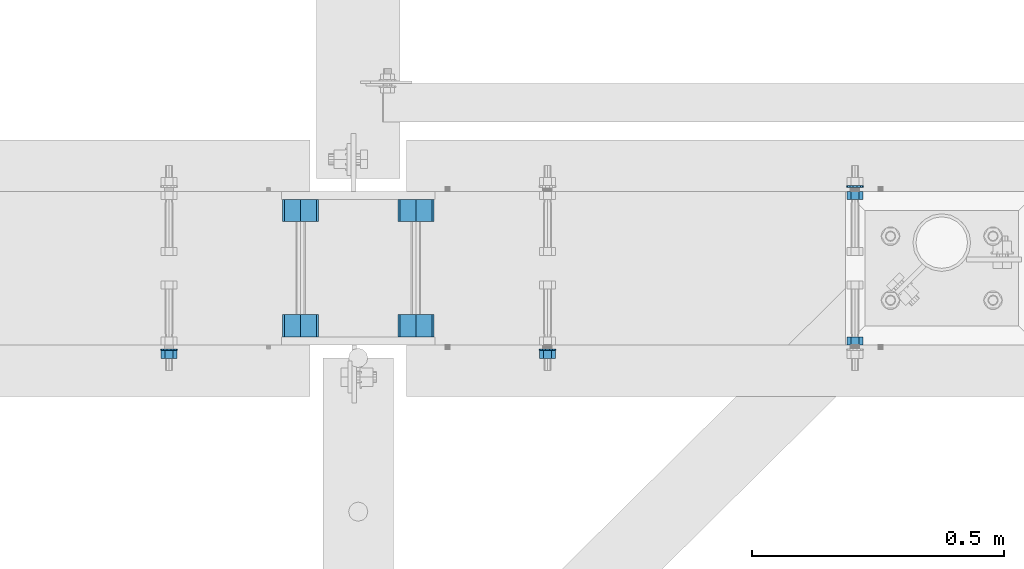
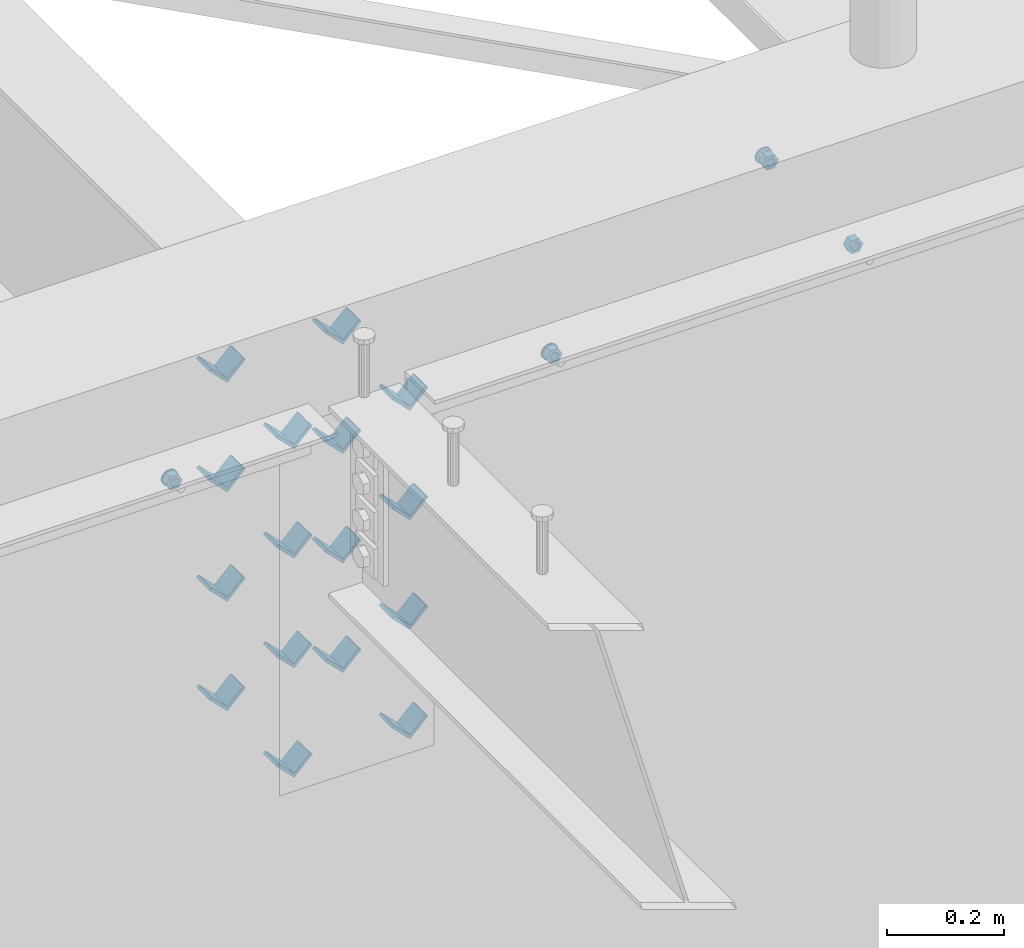
# One storey, part 606 of 975: 23 beams.
"""IFC2X3 building model written with IfcOpenShell, lengths in millimetres."""

import ifcopenshell
import ifcopenshell.guid

model = None  # the IFC model being written
_history = None  # IfcOwnerHistory: only IFC2X3 demands one
_inside = {}  # id of a spatial element -> (the spatial element, [elements in it])
_under = {}  # id of a project, library or spatial element -> (it, [spatial elements below it])
_declared = {}  # id of a project -> (the project, [libraries it declares])
_typed = {}  # id of a type object -> (the type object, [elements of that type])
_made_of = {}  # id of a material, layer set ... -> (it, [elements and type objects made of it])


def new_model(schema):
    """Start an empty IFC model of exactly this schema.

    Asked for "IFC4X3", IfcOpenShell would pick the latest addendum, in which some entities
    have other attributes; the version numbers below select the first issue.
    IFC2X3 requires an IfcOwnerHistory on every rooted entity: one is made here for all.
    """
    global model, _history
    if schema == "IFC4X3":
        model = ifcopenshell.file(schema_version=(4, 3, 0, 0))
    else:
        model = ifcopenshell.file(schema=schema)
    _inside.clear()
    _under.clear()
    _declared.clear()
    _typed.clear()
    _made_of.clear()
    _history = None
    if model.schema == "IFC2X3":
        org = make("IfcOrganization", Name="unknown")
        user = make(
            "IfcPersonAndOrganization",
            ThePerson=make("IfcPerson", FamilyName="unknown"),
            TheOrganization=org,
        )
        app = make(
            "IfcApplication",
            ApplicationDeveloper=org,
            Version="unknown",
            ApplicationFullName="unknown",
            ApplicationIdentifier="unknown",
        )
        _history = make(
            "IfcOwnerHistory",
            OwningUser=user,
            OwningApplication=app,
            ChangeAction="ADDED",
            CreationDate=0,
        )
    return model


def make(cls, **values):
    """One entity of the class cls with the attributes given. An attribute that is None is left unset."""
    return model.create_entity(
        cls, **{name: value for name, value in values.items() if value is not None}
    )


def rooted(cls, **values):
    """An entity with a GlobalId (a new one), such as an element, a storey or a relation."""
    return make(cls, GlobalId=ifcopenshell.guid.new(), OwnerHistory=_history, **values)


def si_unit(unit_type, name, prefix=None):
    """IfcSIUnit, for example si_unit("LENGTHUNIT", "METRE", prefix="MILLI")."""
    return make("IfcSIUnit", UnitType=unit_type, Prefix=prefix, Name=name)


def assignment(units):
    """IfcUnitAssignment: the units of a project."""
    return None if units is None else make("IfcUnitAssignment", Units=units)


def point(xyz):
    """IfcCartesianPoint."""
    return None if xyz is None else make("IfcCartesianPoint", Coordinates=xyz)


def direction(xyz):
    """IfcDirection."""
    return None if xyz is None else make("IfcDirection", DirectionRatios=xyz)


def frame(location, z_axis=None, x_axis=None):
    """IfcAxis2Placement3D, a coordinate frame: its origin and axes. An axis left out is left unset."""
    return make(
        "IfcAxis2Placement3D",
        Location=point(location),
        Axis=direction(z_axis),
        RefDirection=direction(x_axis),
    )


def origin_with_axes():
    """The frame at (0, 0, 0) with the z axis (0, 0, 1) and the x axis (1, 0, 0) written out."""
    return frame((0.0, 0.0, 0.0), z_axis=(0.0, 0.0, 1.0), x_axis=(1.0, 0.0, 0.0))


def place(relative_to, where):
    """IfcLocalPlacement: puts the frame where relative to a parent placement (None: the world)."""
    return make(
        "IfcLocalPlacement", PlacementRelTo=relative_to, RelativePlacement=where
    )


def context(
    kind, dimensions, precision=None, world=None, true_north=None, identifier=None
):
    """IfcGeometricRepresentationContext, for example the 3D "Model" context."""
    return make(
        "IfcGeometricRepresentationContext",
        ContextIdentifier=identifier,
        ContextType=kind,
        CoordinateSpaceDimension=dimensions,
        Precision=precision,
        WorldCoordinateSystem=world,
        TrueNorth=true_north,
    )


def subcontext(parent, identifier, kind, view, scale=None):
    """IfcGeometricRepresentationSubContext, for example "Body" below "Model"."""
    return make(
        "IfcGeometricRepresentationSubContext",
        ContextIdentifier=identifier,
        ContextType=kind,
        ParentContext=parent,
        TargetScale=scale,
        TargetView=view,
    )


def project(units=None, contexts=None):
    """IfcProject with its units and contexts."""
    return rooted(
        "IfcProject",
        Name="project",
        RepresentationContexts=contexts,
        UnitsInContext=assignment(units),
    )


def spatial(cls, under=None, at=None, **own):
    """A site, building, storey or space (cls), placed at a placement, below another one or the project."""
    s = rooted(cls, ObjectPlacement=at, **own)
    if under is not None:
        _under.setdefault(under.id(), (under, []))[1].append(s)
    return s


def faces_of(points, faces, orient=None, outer=None):
    """IfcFace entities. A face is a list of loops; a loop is a list of indices into points, from 0.

    orient and outer hold one flag for each loop. By default every Orientation is true, the
    first loop of a face is its IfcFaceOuterBound and the others are IfcFaceBound.
    """
    made = []
    for i, loops in enumerate(faces):
        bounds = []
        for j, loop in enumerate(loops):
            is_outer = j == 0 if outer is None else outer[i][j]
            bounds.append(
                make(
                    "IfcFaceOuterBound" if is_outer else "IfcFaceBound",
                    Bound=make("IfcPolyLoop", Polygon=[points[k] for k in loop]),
                    Orientation=True if orient is None else orient[i][j],
                )
            )
        made.append(make("IfcFace", Bounds=bounds))
    return made


def faceted_brep(points, faces, orient=None, outer=None, voids=None):
    """IfcFacetedBrep: a solid bounded by flat faces; with voids (closed shells), ...WithVoids."""
    shared = [point(p) for p in points]
    hull = make("IfcClosedShell", CfsFaces=faces_of(shared, faces, orient, outer))
    if voids is None:
        return make("IfcFacetedBrep", Outer=hull)
    return make(
        "IfcFacetedBrepWithVoids",
        Outer=hull,
        Voids=[
            make(cls, CfsFaces=faces_of(shared, fs, o, b)) for cls, fs, o, b in voids
        ],
    )


def shape(context_of_items, identifier, shape_type, items):
    """IfcShapeRepresentation: the items that make up one representation, for example the "Body"."""
    return make(
        "IfcShapeRepresentation",
        ContextOfItems=context_of_items,
        RepresentationIdentifier=identifier,
        RepresentationType=shape_type,
        Items=items,
    )


def material(Name=None, Category=None):
    """IfcMaterial."""
    return make("IfcMaterial", Name=Name, Category=Category)


def made_of(thing, what):
    """Note that an element or type object is made of a material, layer set ...; save() writes the relation."""
    if what is not None:
        _made_of.setdefault(what.id(), (what, []))[1].append(thing)
    return thing


def type_object(cls, material=None, **own):
    """A type object (cls), such as IfcWallType, which elements share."""
    return made_of(rooted(cls, **own), material)


def element(
    cls,
    number,
    at=None,
    inside=None,
    cuts=None,
    type_object=None,
    material=None,
    context=None,
    identifier="Body",
    shape_type=None,
    held_by="IfcProductDefinitionShape",
    body=None,
    shapes=None,
    **own,
):
    """One element of the class cls, such as IfcWall. Its Tag is "e" and its number.

    at: its placement. inside: the storey or other place that contains it. cuts: it is an
    opening in that element (IfcRelVoidsElement). A single representation is given by context,
    identifier, shape_type and body (its items); several are given by shapes. held_by: the class
    of the entity that holds the representations. save() writes the other relations.
    """
    e = rooted(cls, Tag="e%d" % number, ObjectPlacement=at, **own)
    if body is not None:
        shapes = [shape(context, identifier, shape_type, body)]
    if shapes is not None:
        e.Representation = make(held_by, Representations=shapes)
    if inside is not None:
        _inside.setdefault(inside.id(), (inside, []))[1].append(e)
    if cuts is not None:
        rooted(
            "IfcRelVoidsElement", RelatingBuildingElement=cuts, RelatedOpeningElement=e
        )
    if type_object is not None:
        _typed.setdefault(type_object.id(), (type_object, []))[1].append(e)
    return made_of(e, material)


def aggregate(whole, parts):
    """IfcRelAggregates: a whole, such as a stair, and the parts it consists of."""
    return rooted("IfcRelAggregates", RelatingObject=whole, RelatedObjects=parts)


def save(model, path):
    """Write the relations noted so far, then the file.

    IfcRelAggregates (storeys below a building ...), IfcRelContainedInSpatialStructure (elements
    in a storey), IfcRelDefinesByType, IfcRelAssociatesMaterial and IfcRelDeclares: one each for
    every whole, place, type object, material and project.
    """
    for whole, parts in _under.values():
        aggregate(whole, parts)
    for where, things in _inside.values():
        rooted(
            "IfcRelContainedInSpatialStructure",
            RelatedElements=things,
            RelatingStructure=where,
        )
    for kind, things in _typed.values():
        rooted("IfcRelDefinesByType", RelatedObjects=things, RelatingType=kind)
    for what, things in _made_of.values():
        rooted("IfcRelAssociatesMaterial", RelatedObjects=things, RelatingMaterial=what)
    for by, libraries in _declared.values():
        rooted("IfcRelDeclares", RelatingContext=by, RelatedDefinitions=libraries)
    model.write(path)


model = new_model("IFC2X3")

# Units and contexts
model_context = context("Model", 3, precision=1e-05, world=origin_with_axes())
body_context = subcontext(model_context, "Body", "Model", "MODEL_VIEW")
ifc_project = project(units=[si_unit("LENGTHUNIT", "METRE", prefix="MILLI"), si_unit("AREAUNIT", "SQUARE_METRE"), si_unit("VOLUMEUNIT", "CUBIC_METRE"), si_unit("MASSUNIT", "GRAM", prefix="KILO"), si_unit("TIMEUNIT", "SECOND"), si_unit("PLANEANGLEUNIT", "RADIAN"), si_unit("SOLIDANGLEUNIT", "STERADIAN"), si_unit("THERMODYNAMICTEMPERATUREUNIT", "DEGREE_CELSIUS"), si_unit("LUMINOUSINTENSITYUNIT", "LUMEN")], contexts=[model_context])

# Site, building, storey
site_placement = place(None, origin_with_axes())
site = spatial("IfcSite", under=ifc_project, at=site_placement, CompositionType="ELEMENT")
building_placement = place(site_placement, origin_with_axes())
building = spatial("IfcBuilding", under=site, at=building_placement, Name="Undefined", CompositionType="ELEMENT")
storey_placement = place(building_placement, origin_with_axes())
storey = spatial("IfcBuildingStorey", under=building, at=storey_placement, Name="Undefined", CompositionType="ELEMENT", Elevation=0.0)

# Beams
ifc_material = material(Name="STEEL/A36")
beam_type_1 = type_object("IfcBeamType", Name="L2X2X1/4", PredefinedType="NOTDEFINED")
for number, where, z_axis, x_axis, name in (
    (1, (6145.7421482145, 20459.6337290899, 3417.06996517217), (-0.707106781186557, 0.0, 0.707106781186538), (0.0, 1.0, 0.0), "ANGLE"),
    (2, (6374.34214821451, 20459.6337290899, 3417.06996517217), (-0.707106781186557, 0.0, 0.707106781186538), (0.0, 1.0, 0.0), "ANGLE"),
    (3, (6145.7421482145, 20688.3662709102, 3417.06996517217), (-0.707106781186557, 0.0, 0.707106781186538), (0.0, 1.0, 0.0), "ANGLE"),
    (4, (6374.34214821451, 20688.3662709102, 3417.06996517217), (-0.707106781186557, 0.0, 0.707106781186538), (0.0, 1.0, 0.0), "ANGLE"),
    (5, (6145.7421482145, 20459.6337290899, 3645.66996517217), (-0.707106781186557, 0.0, 0.707106781186538), (0.0, 1.0, 0.0), "ANGLE"),
    (6, (6374.34214821451, 20459.6337290899, 3645.66996517217), (-0.707106781186557, 0.0, 0.707106781186538), (0.0, 1.0, 0.0), "ANGLE"),
    (7, (6145.7421482145, 20688.3662709102, 3645.66996517217), (-0.707106781186557, 0.0, 0.707106781186538), (0.0, 1.0, 0.0), "ANGLE"),
    (8, (6374.34214821451, 20688.3662709102, 3645.66996517217), (-0.707106781186557, 0.0, 0.707106781186538), (0.0, 1.0, 0.0), "ANGLE"),
    (9, (6145.74214821337, 20459.6337290899, 3188.4699651707), (-0.707106781186557, 0.0, 0.707106781186538), (0.0, 1.0, 0.0), "ANGLE"),
    (10, (6145.7421482145, 20459.6337290899, 3874.26996517217), (-0.707106781186557, 0.0, 0.707106781186538), (0.0, 1.0, 0.0), "ANGLE"),
    (11, (6374.34214821338, 20459.6337290899, 3188.4699651707), (-0.707106781186557, 0.0, 0.707106781186538), (0.0, 1.0, 0.0), "ANGLE"),
    (12, (6374.34214821451, 20459.6337290899, 3874.26996517217), (-0.707106781186557, 0.0, 0.707106781186538), (0.0, 1.0, 0.0), "ANGLE"),
    (13, (6145.74214821337, 20688.3662709102, 3188.4699651707), (-0.707106781186557, 0.0, 0.707106781186538), (0.0, 1.0, 0.0), "ANGLE"),
    (14, (6145.7421482145, 20688.3662709102, 3874.26996517217), (-0.707106781186557, 0.0, 0.707106781186538), (0.0, 1.0, 0.0), "ANGLE"),
    (15, (6374.34214821338, 20688.3662709102, 3188.4699651707), (-0.707106781186557, 0.0, 0.707106781186538), (0.0, 1.0, 0.0), "ANGLE"),
    (16, (6374.34214821451, 20688.3662709102, 3874.26996517217), (-0.707106781186557, 0.0, 0.707106781186538), (0.0, 1.0, 0.0), "ANGLE"),
):
    element("IfcBeam", number, at=place(storey_placement, frame(where, z_axis=z_axis, x_axis=x_axis)), inside=storey, type_object=beam_type_1, material=ifc_material, Name=name, ObjectType="L2X2X1/4", context=body_context, shape_type="Brep", body=[
        faceted_brep([(0.0, 25.3999999999724, -25.4000000000342), (0.0, 25.400000000016, 25.4000000000196), (44.4499999999971, 25.4000000000033, 25.4000000000051), (44.4499999999971, 25.4000000000033, -25.4000000000024), (3.27418092638254e-11, 19.0500000000002, 25.4000000000269), (44.4499999999971, 19.0500000000011, 25.400000000006), (-2.5465851649642e-11, 19.0500000000002, -19.0500000000211), (44.4499999999971, 19.0500000000011, -19.050000000002), (-2.5465851649642e-11, -25.3999999999996, -19.0500000000211), (44.4499999999971, -25.4000000000069, -19.0500000000038), (0.0, -25.400000000016, -25.4000000000196), (44.4499999999971, -25.4000000000069, -25.4000000000033)], [[[0, 1, 2, 3]], [[1, 4, 5, 2]], [[4, 6, 7, 5]], [[6, 8, 9, 7]], [[8, 10, 11, 9]], [[10, 0, 3, 11]], [[5, 7, 9, 11, 3, 2]], [[10, 8, 6, 4, 1, 0]]]),
    ])
beam_type_2 = type_object("IfcBeamType", Name="5/8_HEAVY_HEX_NUT", PredefinedType="NOTDEFINED")
beam_1_placement = place(storey_placement, frame((7244.82086460168, 20443.825, 3886.2), z_axis=(0.0, 0.0, -1.0), x_axis=(0.0, 1.0, 0.0)))
element("IfcBeam", 17, at=beam_1_placement, inside=storey, type_object=beam_type_2, material=ifc_material, Name="NUT", ObjectType="5/8_HEAVY_HEX_NUT", context=body_context, shape_type="Brep", body=[
    faceted_brep([(-1.09139364212751e-11, -15.8800001144436, -2.72848410531878e-12), (1.45519152283669e-11, -7.94000005722046, -13.7500000000036), (15.8750000000146, -7.94000005722137, -13.7500000000045), (15.8749999999891, -15.8800001144446, -2.72848410531878e-12), (2.91038304567337e-11, 7.94000005722319, -13.7500000000027), (15.8750000000291, 7.94000005722319, -13.7500000000027), (2.18278728425503e-11, 15.8800001144436, 9.09494701772928e-13), (15.8750000000218, 15.8800001144427, 9.09494701772928e-13), (-7.27595761418343e-12, 7.94000005722046, 13.7500000000027), (15.8749999999927, 7.94000005722046, 13.7500000000027), (-2.18278728425503e-11, -7.94000005722228, 13.7500000000009), (15.8749999999782, -7.94000005722319, 13.7500000000009), (-7.27595761418343e-12, 0.0, 8.72999954223724), (0.0, 3.78780484388062, 7.86545780435881), (15.875, 3.78780484387971, 7.86545780435881), (15.8749999999927, -9.09494701772928e-13, 8.72999954223724), (7.27595761418343e-12, 6.82538848405238, 5.44306568481716), (15.8750000000073, 6.82538848405238, 5.44306568481716), (1.09139364212751e-11, 8.51112022706275, 1.94260765157742), (15.8750000000109, 8.51112022706093, 1.94260765157651), (1.45519152283669e-11, 8.51112022706184, -1.94260765157651), (15.8750000000146, 8.51112022706184, -1.94260765157651), (2.18278728425503e-11, 6.8253884840542, -5.44306568481716), (15.8750000000218, 6.82538848405238, -5.44306568481716), (1.81898940354586e-11, 3.78780484388153, -7.86545780435881), (15.8750000000182, 3.78780484388062, -7.86545780435881), (1.81898940354586e-11, 9.09494701772928e-13, -8.72999954223997), (15.8750000000182, 9.09494701772928e-13, -8.72999954223997), (1.09139364212751e-11, -3.78780484387971, -7.86545780436063), (15.8750000000109, -3.78780484388062, -7.86545780436063), (3.63797880709171e-12, -6.82538848405238, -5.44306568481807), (15.8750000000036, -6.82538848405329, -5.44306568481807), (0.0, -8.51112022706184, -1.94260765157833), (15.875, -8.51112022706184, -1.94260765157833), (-7.27595761418343e-12, -8.51112022706184, 1.9426076515756), (15.8749999999927, -8.51112022706275, 1.9426076515756), (-1.09139364212751e-11, -6.82538848405329, 5.44306568481534), (15.8749999999927, -6.8253884840542, 5.44306568481534), (-7.27595761418343e-12, -3.78780484388062, 7.8654578043579), (15.8749999999927, -3.78780484388153, 7.8654578043579)], [[[0, 1, 2, 3]], [[1, 4, 5, 2]], [[4, 6, 7, 5]], [[6, 8, 9, 7]], [[8, 10, 11, 9]], [[10, 0, 3, 11]], [[12, 13, 14, 15]], [[13, 16, 17, 14]], [[16, 18, 19, 17]], [[18, 20, 21, 19]], [[20, 22, 23, 21]], [[22, 24, 25, 23]], [[24, 26, 27, 25]], [[26, 28, 29, 27]], [[28, 30, 31, 29]], [[30, 32, 33, 31]], [[32, 34, 35, 33]], [[34, 36, 37, 35]], [[36, 38, 39, 37]], [[38, 12, 15, 39]], [[5, 7, 9, 11, 3, 2], [17, 19, 21, 23, 25, 27, 29, 31, 33, 35, 37, 39, 15, 14]], [[10, 8, 6, 4, 1, 0], [38, 36, 34, 32, 30, 28, 26, 24, 22, 20, 18, 16, 13, 12]]]),
])
beam_2_placement = place(storey_placement, frame((7244.82086460168, 20748.6249996637, 3886.2), z_axis=(0.0, 0.0, 1.0), x_axis=(0.0, -1.0, 0.0)))
element("IfcBeam", 18, at=beam_2_placement, inside=storey, type_object=beam_type_2, material=ifc_material, Name="NUT", ObjectType="5/8_HEAVY_HEX_NUT", context=body_context, shape_type="Brep", body=[
    faceted_brep([(-1.09139364212751e-11, -15.8800001144436, -2.72848410531878e-12), (1.45519152283669e-11, -7.94000005722046, -13.7500000000036), (15.8750000000146, -7.94000005722137, -13.7500000000045), (15.8749999999891, -15.8800001144446, -2.72848410531878e-12), (2.91038304567337e-11, 7.94000005722319, -13.7500000000027), (15.8750000000291, 7.94000005722319, -13.7500000000027), (2.18278728425503e-11, 15.8800001144436, 9.09494701772928e-13), (15.8750000000218, 15.8800001144427, 9.09494701772928e-13), (-7.27595761418343e-12, 7.94000005722046, 13.7500000000027), (15.8749999999927, 7.94000005722046, 13.7500000000027), (-2.18278728425503e-11, -7.94000005722228, 13.7500000000009), (15.8749999999782, -7.94000005722319, 13.7500000000009), (-7.27595761418343e-12, 0.0, 8.72999954223724), (0.0, 3.78780484388062, 7.86545780435881), (15.875, 3.78780484387971, 7.86545780435881), (15.8749999999927, -9.09494701772928e-13, 8.72999954223724), (7.27595761418343e-12, 6.82538848405238, 5.44306568481716), (15.8750000000073, 6.82538848405238, 5.44306568481716), (1.09139364212751e-11, 8.51112022706275, 1.94260765157742), (15.8750000000109, 8.51112022706093, 1.94260765157651), (1.45519152283669e-11, 8.51112022706184, -1.94260765157651), (15.8750000000146, 8.51112022706184, -1.94260765157651), (2.18278728425503e-11, 6.8253884840542, -5.44306568481716), (15.8750000000218, 6.82538848405238, -5.44306568481716), (1.81898940354586e-11, 3.78780484388153, -7.86545780435881), (15.8750000000182, 3.78780484388062, -7.86545780435881), (1.81898940354586e-11, 9.09494701772928e-13, -8.72999954223997), (15.8750000000182, 9.09494701772928e-13, -8.72999954223997), (1.09139364212751e-11, -3.78780484387971, -7.86545780436063), (15.8750000000109, -3.78780484388062, -7.86545780436063), (3.63797880709171e-12, -6.82538848405238, -5.44306568481807), (15.8750000000036, -6.82538848405329, -5.44306568481807), (0.0, -8.51112022706184, -1.94260765157833), (15.875, -8.51112022706184, -1.94260765157833), (-7.27595761418343e-12, -8.51112022706184, 1.9426076515756), (15.8749999999927, -8.51112022706275, 1.9426076515756), (-1.09139364212751e-11, -6.82538848405329, 5.44306568481534), (15.8749999999927, -6.8253884840542, 5.44306568481534), (-7.27595761418343e-12, -3.78780484388062, 7.8654578043579), (15.8749999999927, -3.78780484388153, 7.8654578043579)], [[[0, 1, 2, 3]], [[1, 4, 5, 2]], [[4, 6, 7, 5]], [[6, 8, 9, 7]], [[8, 10, 11, 9]], [[10, 0, 3, 11]], [[12, 13, 14, 15]], [[13, 16, 17, 14]], [[16, 18, 19, 17]], [[18, 20, 21, 19]], [[20, 22, 23, 21]], [[22, 24, 25, 23]], [[24, 26, 27, 25]], [[26, 28, 29, 27]], [[28, 30, 31, 29]], [[30, 32, 33, 31]], [[32, 34, 35, 33]], [[34, 36, 37, 35]], [[36, 38, 39, 37]], [[38, 12, 15, 39]], [[5, 7, 9, 11, 3, 2], [17, 19, 21, 23, 25, 27, 29, 31, 33, 35, 37, 39, 15, 14]], [[10, 8, 6, 4, 1, 0], [38, 36, 34, 32, 30, 28, 26, 24, 22, 20, 18, 16, 13, 12]]]),
])
beam_3_placement = place(storey_placement, frame((6635.22088901577, 20416.8375, 3886.2), z_axis=(0.0, 0.0, -1.0), x_axis=(0.0, 1.0, 0.0)))
element("IfcBeam", 19, at=beam_3_placement, inside=storey, type_object=beam_type_2, material=ifc_material, Name="NUT", ObjectType="5/8_HEAVY_HEX_NUT", context=body_context, shape_type="Brep", body=[
    faceted_brep([(-1.09139364212751e-11, -15.8800001144436, -2.72848410531878e-12), (1.45519152283669e-11, -7.94000005722046, -13.7500000000036), (15.8750000000146, -7.94000005722137, -13.7500000000045), (15.8749999999891, -15.8800001144446, -2.72848410531878e-12), (2.91038304567337e-11, 7.94000005722319, -13.7500000000027), (15.8750000000291, 7.94000005722319, -13.7500000000027), (2.18278728425503e-11, 15.8800001144436, 9.09494701772928e-13), (15.8750000000218, 15.8800001144427, 9.09494701772928e-13), (-7.27595761418343e-12, 7.94000005722046, 13.7500000000027), (15.8749999999927, 7.94000005722046, 13.7500000000027), (-2.18278728425503e-11, -7.94000005722228, 13.7500000000009), (15.8749999999782, -7.94000005722319, 13.7500000000009), (-7.27595761418343e-12, 0.0, 8.72999954223724), (0.0, 3.78780484388062, 7.86545780435881), (15.875, 3.78780484387971, 7.86545780435881), (15.8749999999927, -9.09494701772928e-13, 8.72999954223724), (7.27595761418343e-12, 6.82538848405238, 5.44306568481716), (15.8750000000073, 6.82538848405238, 5.44306568481716), (1.09139364212751e-11, 8.51112022706275, 1.94260765157742), (15.8750000000109, 8.51112022706093, 1.94260765157651), (1.45519152283669e-11, 8.51112022706184, -1.94260765157651), (15.8750000000146, 8.51112022706184, -1.94260765157651), (2.18278728425503e-11, 6.8253884840542, -5.44306568481716), (15.8750000000218, 6.82538848405238, -5.44306568481716), (1.81898940354586e-11, 3.78780484388153, -7.86545780435881), (15.8750000000182, 3.78780484388062, -7.86545780435881), (1.81898940354586e-11, 9.09494701772928e-13, -8.72999954223997), (15.8750000000182, 9.09494701772928e-13, -8.72999954223997), (1.09139364212751e-11, -3.78780484387971, -7.86545780436063), (15.8750000000109, -3.78780484388062, -7.86545780436063), (3.63797880709171e-12, -6.82538848405238, -5.44306568481807), (15.8750000000036, -6.82538848405329, -5.44306568481807), (0.0, -8.51112022706184, -1.94260765157833), (15.875, -8.51112022706184, -1.94260765157833), (-7.27595761418343e-12, -8.51112022706184, 1.9426076515756), (15.8749999999927, -8.51112022706275, 1.9426076515756), (-1.09139364212751e-11, -6.82538848405329, 5.44306568481534), (15.8749999999927, -6.8253884840542, 5.44306568481534), (-7.27595761418343e-12, -3.78780484388062, 7.8654578043579), (15.8749999999927, -3.78780484388153, 7.8654578043579)], [[[0, 1, 2, 3]], [[1, 4, 5, 2]], [[4, 6, 7, 5]], [[6, 8, 9, 7]], [[8, 10, 11, 9]], [[10, 0, 3, 11]], [[12, 13, 14, 15]], [[13, 16, 17, 14]], [[16, 18, 19, 17]], [[18, 20, 21, 19]], [[20, 22, 23, 21]], [[22, 24, 25, 23]], [[24, 26, 27, 25]], [[26, 28, 29, 27]], [[28, 30, 31, 29]], [[30, 32, 33, 31]], [[32, 34, 35, 33]], [[34, 36, 37, 35]], [[36, 38, 39, 37]], [[38, 12, 15, 39]], [[5, 7, 9, 11, 3, 2], [17, 19, 21, 23, 25, 27, 29, 31, 33, 35, 37, 39, 15, 14]], [[10, 8, 6, 4, 1, 0], [38, 36, 34, 32, 30, 28, 26, 24, 22, 20, 18, 16, 13, 12]]]),
])
beam_4_placement = place(storey_placement, frame((5884.86256939268, 20416.8375, 3886.2), z_axis=(0.0, 0.0, 1.0), x_axis=(0.0, 1.0, 0.0)))
element("IfcBeam", 20, at=beam_4_placement, inside=storey, type_object=beam_type_2, material=ifc_material, Name="NUT", ObjectType="5/8_HEAVY_HEX_NUT", context=body_context, shape_type="Brep", body=[
    faceted_brep([(-1.09139364212751e-11, -15.8800001144436, -2.72848410531878e-12), (1.45519152283669e-11, -7.94000005722046, -13.7500000000036), (15.8750000000146, -7.94000005722137, -13.7500000000045), (15.8749999999891, -15.8800001144446, -2.72848410531878e-12), (2.91038304567337e-11, 7.94000005722319, -13.7500000000027), (15.8750000000291, 7.94000005722319, -13.7500000000027), (2.18278728425503e-11, 15.8800001144436, 9.09494701772928e-13), (15.8750000000218, 15.8800001144427, 9.09494701772928e-13), (-7.27595761418343e-12, 7.94000005722046, 13.7500000000027), (15.8749999999927, 7.94000005722046, 13.7500000000027), (-2.18278728425503e-11, -7.94000005722228, 13.7500000000009), (15.8749999999782, -7.94000005722319, 13.7500000000009), (-7.27595761418343e-12, 0.0, 8.72999954223724), (0.0, 3.78780484388062, 7.86545780435881), (15.875, 3.78780484387971, 7.86545780435881), (15.8749999999927, -9.09494701772928e-13, 8.72999954223724), (7.27595761418343e-12, 6.82538848405238, 5.44306568481716), (15.8750000000073, 6.82538848405238, 5.44306568481716), (1.09139364212751e-11, 8.51112022706275, 1.94260765157742), (15.8750000000109, 8.51112022706093, 1.94260765157651), (1.45519152283669e-11, 8.51112022706184, -1.94260765157651), (15.8750000000146, 8.51112022706184, -1.94260765157651), (2.18278728425503e-11, 6.8253884840542, -5.44306568481716), (15.8750000000218, 6.82538848405238, -5.44306568481716), (1.81898940354586e-11, 3.78780484388153, -7.86545780435881), (15.8750000000182, 3.78780484388062, -7.86545780435881), (1.81898940354586e-11, 9.09494701772928e-13, -8.72999954223997), (15.8750000000182, 9.09494701772928e-13, -8.72999954223997), (1.09139364212751e-11, -3.78780484387971, -7.86545780436063), (15.8750000000109, -3.78780484388062, -7.86545780436063), (3.63797880709171e-12, -6.82538848405238, -5.44306568481807), (15.8750000000036, -6.82538848405329, -5.44306568481807), (0.0, -8.51112022706184, -1.94260765157833), (15.875, -8.51112022706184, -1.94260765157833), (-7.27595761418343e-12, -8.51112022706184, 1.9426076515756), (15.8749999999927, -8.51112022706275, 1.9426076515756), (-1.09139364212751e-11, -6.82538848405329, 5.44306568481534), (15.8749999999927, -6.8253884840542, 5.44306568481534), (-7.27595761418343e-12, -3.78780484388062, 7.8654578043579), (15.8749999999927, -3.78780484388153, 7.8654578043579)], [[[0, 1, 2, 3]], [[1, 4, 5, 2]], [[4, 6, 7, 5]], [[6, 8, 9, 7]], [[8, 10, 11, 9]], [[10, 0, 3, 11]], [[12, 13, 14, 15]], [[13, 16, 17, 14]], [[16, 18, 19, 17]], [[18, 20, 21, 19]], [[20, 22, 23, 21]], [[22, 24, 25, 23]], [[24, 26, 27, 25]], [[26, 28, 29, 27]], [[28, 30, 31, 29]], [[30, 32, 33, 31]], [[32, 34, 35, 33]], [[34, 36, 37, 35]], [[36, 38, 39, 37]], [[38, 12, 15, 39]], [[5, 7, 9, 11, 3, 2], [17, 19, 21, 23, 25, 27, 29, 31, 33, 35, 37, 39, 15, 14]], [[10, 8, 6, 4, 1, 0], [38, 36, 34, 32, 30, 28, 26, 24, 22, 20, 18, 16, 13, 12]]]),
])
beam_type_3 = type_object("IfcBeamType", Name="5/8_WASHER", PredefinedType="NOTDEFINED")
beam_5_placement = place(storey_placement, frame((7244.82086460174, 20759.7375, 3886.2), z_axis=(0.0, 0.0, 1.0), x_axis=(0.0, -1.0, 0.0)))
element("IfcBeam", 21, at=beam_5_placement, inside=storey, type_object=beam_type_3, material=ifc_material, Name="WASHER", ObjectType="5/8_WASHER", context=body_context, shape_type="Brep", body=[
    faceted_brep([(1.09139364212751e-11, -16.670000076293, -2.72848410531878e-12), (2.18278728425503e-11, -15.0191510966704, -7.23284196419536), (3.1750000000211, -15.0191510966711, -7.23284196419627), (3.17500000001019, -16.6700000762937, -1.81898940354586e-12), (2.91038304567337e-11, -10.3935750445523, -13.0331308723944), (3.17500000002838, -10.3935750445526, -13.0331308723953), (2.91038304567337e-11, -3.70942398602756, -16.2520483704566), (3.17500000002838, -3.70942398602779, -16.2520483704566), (2.5465851649642e-11, 3.70942398602961, -16.2520483704557), (3.17500000002474, 3.70942398602961, -16.2520483704566), (1.45519152283669e-11, 10.3935750445542, -13.0331308723935), (3.17500000001382, 10.3935750445537, -13.0331308723944), (0.0, 15.0191510966717, -7.23284196419354), (3.17499999999927, 15.0191510966713, -7.23284196419354), (-7.27595761418343e-12, 16.6700000762933, 0.0), (3.174999999992, 16.6700000762928, -9.09494701772928e-13), (-1.81898940354586e-11, 15.0191510966706, 7.23284196419354), (3.17499999998108, 15.0191510966704, 7.23284196419354), (-2.5465851649642e-11, 10.3935750445519, 13.0331308723926), (3.17499999997381, 10.3935750445517, 13.0331308723926), (-2.5465851649642e-11, 3.70942398602733, 16.2520483704538), (3.17499999997381, 3.7094239860271, 16.2520483704529), (-2.18278728425503e-11, -3.70942398602983, 16.2520483704529), (3.17499999997744, -3.70942398603006, 16.2520483704538), (-1.09139364212751e-11, -10.3935750445542, 13.0331308723908), (3.17499999998836, -10.3935750445544, 13.0331308723908), (0.0, -15.0191510966717, 7.23284196419172), (3.17499999999927, -15.019151096672, 7.23284196419081), (-7.27595761418343e-12, 0.0, 8.72999954223724), (0.0, 3.78780484388062, 7.86545780435881), (3.17499999998472, 3.78780484387903, 7.86545780435699), (3.17499999998836, -9.09494701772928e-13, 8.72999954223542), (7.27595761418343e-12, 6.82538848405238, 5.44306568481716), (3.17499999998836, 6.82538848405102, 5.44306568481534), (1.09139364212751e-11, 8.51112022706275, 1.94260765157742), (3.174999999992, 8.51112022705979, 1.94260765157651), (1.45519152283669e-11, 8.51112022706184, -1.94260765157651), (3.17499999999563, 8.51112022706025, -1.94260765157742), (2.18278728425503e-11, 6.8253884840542, -5.44306568481716), (3.17500000000655, 6.8253884840517, -5.44306568481807), (1.81898940354586e-11, 3.78780484388153, -7.86545780435881), (3.17500000001019, 3.78780484388017, -7.86545780435972), (1.81898940354586e-11, 9.09494701772928e-13, -8.72999954223997), (3.17500000001382, 6.82121026329696e-13, -8.72999954223997), (1.09139364212751e-11, -3.78780484387971, -7.86545780436063), (3.17500000001382, -3.78780484387994, -7.86545780436063), (3.63797880709171e-12, -6.82538848405238, -5.44306568481807), (3.17500000001019, -6.82538848405147, -5.44306568481898), (0.0, -8.51112022706184, -1.94260765157833), (3.17500000001019, -8.5111202270607, -1.94260765157924), (-7.27595761418343e-12, -8.51112022706184, 1.9426076515756), (3.17500000000291, -8.51112022706093, 1.94260765157469), (-1.09139364212751e-11, -6.82538848405329, 5.44306568481534), (3.17499999999563, -6.82538848405238, 5.44306568481534), (-7.27595761418343e-12, -3.78780484388062, 7.8654578043579), (3.174999999992, -3.78780484388085, 7.86545780435699)], [[[0, 1, 2, 3]], [[1, 4, 5, 2]], [[4, 6, 7, 5]], [[6, 8, 9, 7]], [[8, 10, 11, 9]], [[10, 12, 13, 11]], [[12, 14, 15, 13]], [[14, 16, 17, 15]], [[16, 18, 19, 17]], [[18, 20, 21, 19]], [[20, 22, 23, 21]], [[22, 24, 25, 23]], [[24, 26, 27, 25]], [[26, 0, 3, 27]], [[28, 29, 30, 31]], [[29, 32, 33, 30]], [[32, 34, 35, 33]], [[34, 36, 37, 35]], [[36, 38, 39, 37]], [[38, 40, 41, 39]], [[40, 42, 43, 41]], [[42, 44, 45, 43]], [[44, 46, 47, 45]], [[46, 48, 49, 47]], [[48, 50, 51, 49]], [[50, 52, 53, 51]], [[52, 54, 55, 53]], [[54, 28, 31, 55]], [[5, 7, 9, 11, 13, 15, 17, 19, 21, 23, 25, 27, 3, 2], [33, 35, 37, 39, 41, 43, 45, 47, 49, 51, 53, 55, 31, 30]], [[26, 24, 22, 20, 18, 16, 14, 12, 10, 8, 6, 4, 1, 0], [54, 52, 50, 48, 46, 44, 42, 40, 38, 36, 34, 32, 29, 28]]]),
])
beam_6_placement = place(storey_placement, frame((6635.22088901581, 20432.7125, 3886.2), z_axis=(0.0, 0.0, -1.0), x_axis=(0.0, 1.0, 0.0)))
element("IfcBeam", 22, at=beam_6_placement, inside=storey, type_object=beam_type_3, material=ifc_material, Name="WASHER", ObjectType="5/8_WASHER", context=body_context, shape_type="Brep", body=[
    faceted_brep([(1.09139364212751e-11, -16.670000076293, -2.72848410531878e-12), (2.18278728425503e-11, -15.0191510966704, -7.23284196419536), (3.1750000000211, -15.0191510966711, -7.23284196419627), (3.17500000001019, -16.6700000762937, -1.81898940354586e-12), (2.91038304567337e-11, -10.3935750445523, -13.0331308723944), (3.17500000002838, -10.3935750445526, -13.0331308723953), (2.91038304567337e-11, -3.70942398602756, -16.2520483704566), (3.17500000002838, -3.70942398602779, -16.2520483704566), (2.5465851649642e-11, 3.70942398602961, -16.2520483704557), (3.17500000002474, 3.70942398602961, -16.2520483704566), (1.45519152283669e-11, 10.3935750445542, -13.0331308723935), (3.17500000001382, 10.3935750445537, -13.0331308723944), (0.0, 15.0191510966717, -7.23284196419354), (3.17499999999927, 15.0191510966713, -7.23284196419354), (-7.27595761418343e-12, 16.6700000762933, 0.0), (3.174999999992, 16.6700000762928, -9.09494701772928e-13), (-1.81898940354586e-11, 15.0191510966706, 7.23284196419354), (3.17499999998108, 15.0191510966704, 7.23284196419354), (-2.5465851649642e-11, 10.3935750445519, 13.0331308723926), (3.17499999997381, 10.3935750445517, 13.0331308723926), (-2.5465851649642e-11, 3.70942398602733, 16.2520483704538), (3.17499999997381, 3.7094239860271, 16.2520483704529), (-2.18278728425503e-11, -3.70942398602983, 16.2520483704529), (3.17499999997744, -3.70942398603006, 16.2520483704538), (-1.09139364212751e-11, -10.3935750445542, 13.0331308723908), (3.17499999998836, -10.3935750445544, 13.0331308723908), (0.0, -15.0191510966717, 7.23284196419172), (3.17499999999927, -15.019151096672, 7.23284196419081), (-7.27595761418343e-12, 0.0, 8.72999954223724), (0.0, 3.78780484388062, 7.86545780435881), (3.17499999998472, 3.78780484387903, 7.86545780435699), (3.17499999998836, -9.09494701772928e-13, 8.72999954223542), (7.27595761418343e-12, 6.82538848405238, 5.44306568481716), (3.17499999998836, 6.82538848405102, 5.44306568481534), (1.09139364212751e-11, 8.51112022706275, 1.94260765157742), (3.174999999992, 8.51112022705979, 1.94260765157651), (1.45519152283669e-11, 8.51112022706184, -1.94260765157651), (3.17499999999563, 8.51112022706025, -1.94260765157742), (2.18278728425503e-11, 6.8253884840542, -5.44306568481716), (3.17500000000655, 6.8253884840517, -5.44306568481807), (1.81898940354586e-11, 3.78780484388153, -7.86545780435881), (3.17500000001019, 3.78780484388017, -7.86545780435972), (1.81898940354586e-11, 9.09494701772928e-13, -8.72999954223997), (3.17500000001382, 6.82121026329696e-13, -8.72999954223997), (1.09139364212751e-11, -3.78780484387971, -7.86545780436063), (3.17500000001382, -3.78780484387994, -7.86545780436063), (3.63797880709171e-12, -6.82538848405238, -5.44306568481807), (3.17500000001019, -6.82538848405147, -5.44306568481898), (0.0, -8.51112022706184, -1.94260765157833), (3.17500000001019, -8.5111202270607, -1.94260765157924), (-7.27595761418343e-12, -8.51112022706184, 1.9426076515756), (3.17500000000291, -8.51112022706093, 1.94260765157469), (-1.09139364212751e-11, -6.82538848405329, 5.44306568481534), (3.17499999999563, -6.82538848405238, 5.44306568481534), (-7.27595761418343e-12, -3.78780484388062, 7.8654578043579), (3.174999999992, -3.78780484388085, 7.86545780435699)], [[[0, 1, 2, 3]], [[1, 4, 5, 2]], [[4, 6, 7, 5]], [[6, 8, 9, 7]], [[8, 10, 11, 9]], [[10, 12, 13, 11]], [[12, 14, 15, 13]], [[14, 16, 17, 15]], [[16, 18, 19, 17]], [[18, 20, 21, 19]], [[20, 22, 23, 21]], [[22, 24, 25, 23]], [[24, 26, 27, 25]], [[26, 0, 3, 27]], [[28, 29, 30, 31]], [[29, 32, 33, 30]], [[32, 34, 35, 33]], [[34, 36, 37, 35]], [[36, 38, 39, 37]], [[38, 40, 41, 39]], [[40, 42, 43, 41]], [[42, 44, 45, 43]], [[44, 46, 47, 45]], [[46, 48, 49, 47]], [[48, 50, 51, 49]], [[50, 52, 53, 51]], [[52, 54, 55, 53]], [[54, 28, 31, 55]], [[5, 7, 9, 11, 13, 15, 17, 19, 21, 23, 25, 27, 3, 2], [33, 35, 37, 39, 41, 43, 45, 47, 49, 51, 53, 55, 31, 30]], [[26, 24, 22, 20, 18, 16, 14, 12, 10, 8, 6, 4, 1, 0], [54, 52, 50, 48, 46, 44, 42, 40, 38, 36, 34, 32, 29, 28]]]),
])
beam_7_placement = place(storey_placement, frame((5884.86256939269, 20432.7125, 3886.2), z_axis=(0.0, 0.0, 1.0), x_axis=(0.0, 1.0, 0.0)))
element("IfcBeam", 23, at=beam_7_placement, inside=storey, type_object=beam_type_3, material=ifc_material, Name="WASHER", ObjectType="5/8_WASHER", context=body_context, shape_type="Brep", body=[
    faceted_brep([(1.09139364212751e-11, -16.670000076293, -2.72848410531878e-12), (2.18278728425503e-11, -15.0191510966704, -7.23284196419536), (3.1750000000211, -15.0191510966711, -7.23284196419627), (3.17500000001019, -16.6700000762937, -1.81898940354586e-12), (2.91038304567337e-11, -10.3935750445523, -13.0331308723944), (3.17500000002838, -10.3935750445526, -13.0331308723953), (2.91038304567337e-11, -3.70942398602756, -16.2520483704566), (3.17500000002838, -3.70942398602779, -16.2520483704566), (2.5465851649642e-11, 3.70942398602961, -16.2520483704557), (3.17500000002474, 3.70942398602961, -16.2520483704566), (1.45519152283669e-11, 10.3935750445542, -13.0331308723935), (3.17500000001382, 10.3935750445537, -13.0331308723944), (0.0, 15.0191510966717, -7.23284196419354), (3.17499999999927, 15.0191510966713, -7.23284196419354), (-7.27595761418343e-12, 16.6700000762933, 0.0), (3.174999999992, 16.6700000762928, -9.09494701772928e-13), (-1.81898940354586e-11, 15.0191510966706, 7.23284196419354), (3.17499999998108, 15.0191510966704, 7.23284196419354), (-2.5465851649642e-11, 10.3935750445519, 13.0331308723926), (3.17499999997381, 10.3935750445517, 13.0331308723926), (-2.5465851649642e-11, 3.70942398602733, 16.2520483704538), (3.17499999997381, 3.7094239860271, 16.2520483704529), (-2.18278728425503e-11, -3.70942398602983, 16.2520483704529), (3.17499999997744, -3.70942398603006, 16.2520483704538), (-1.09139364212751e-11, -10.3935750445542, 13.0331308723908), (3.17499999998836, -10.3935750445544, 13.0331308723908), (0.0, -15.0191510966717, 7.23284196419172), (3.17499999999927, -15.019151096672, 7.23284196419081), (-7.27595761418343e-12, 0.0, 8.72999954223724), (0.0, 3.78780484388062, 7.86545780435881), (3.17499999998472, 3.78780484387903, 7.86545780435699), (3.17499999998836, -9.09494701772928e-13, 8.72999954223542), (7.27595761418343e-12, 6.82538848405238, 5.44306568481716), (3.17499999998836, 6.82538848405102, 5.44306568481534), (1.09139364212751e-11, 8.51112022706275, 1.94260765157742), (3.174999999992, 8.51112022705979, 1.94260765157651), (1.45519152283669e-11, 8.51112022706184, -1.94260765157651), (3.17499999999563, 8.51112022706025, -1.94260765157742), (2.18278728425503e-11, 6.8253884840542, -5.44306568481716), (3.17500000000655, 6.8253884840517, -5.44306568481807), (1.81898940354586e-11, 3.78780484388153, -7.86545780435881), (3.17500000001019, 3.78780484388017, -7.86545780435972), (1.81898940354586e-11, 9.09494701772928e-13, -8.72999954223997), (3.17500000001382, 6.82121026329696e-13, -8.72999954223997), (1.09139364212751e-11, -3.78780484387971, -7.86545780436063), (3.17500000001382, -3.78780484387994, -7.86545780436063), (3.63797880709171e-12, -6.82538848405238, -5.44306568481807), (3.17500000001019, -6.82538848405147, -5.44306568481898), (0.0, -8.51112022706184, -1.94260765157833), (3.17500000001019, -8.5111202270607, -1.94260765157924), (-7.27595761418343e-12, -8.51112022706184, 1.9426076515756), (3.17500000000291, -8.51112022706093, 1.94260765157469), (-1.09139364212751e-11, -6.82538848405329, 5.44306568481534), (3.17499999999563, -6.82538848405238, 5.44306568481534), (-7.27595761418343e-12, -3.78780484388062, 7.8654578043579), (3.174999999992, -3.78780484388085, 7.86545780435699)], [[[0, 1, 2, 3]], [[1, 4, 5, 2]], [[4, 6, 7, 5]], [[6, 8, 9, 7]], [[8, 10, 11, 9]], [[10, 12, 13, 11]], [[12, 14, 15, 13]], [[14, 16, 17, 15]], [[16, 18, 19, 17]], [[18, 20, 21, 19]], [[20, 22, 23, 21]], [[22, 24, 25, 23]], [[24, 26, 27, 25]], [[26, 0, 3, 27]], [[28, 29, 30, 31]], [[29, 32, 33, 30]], [[32, 34, 35, 33]], [[34, 36, 37, 35]], [[36, 38, 39, 37]], [[38, 40, 41, 39]], [[40, 42, 43, 41]], [[42, 44, 45, 43]], [[44, 46, 47, 45]], [[46, 48, 49, 47]], [[48, 50, 51, 49]], [[50, 52, 53, 51]], [[52, 54, 55, 53]], [[54, 28, 31, 55]], [[5, 7, 9, 11, 13, 15, 17, 19, 21, 23, 25, 27, 3, 2], [33, 35, 37, 39, 41, 43, 45, 47, 49, 51, 53, 55, 31, 30]], [[26, 24, 22, 20, 18, 16, 14, 12, 10, 8, 6, 4, 1, 0], [54, 52, 50, 48, 46, 44, 42, 40, 38, 36, 34, 32, 29, 28]]]),
])

save(model, "model.ifc")
